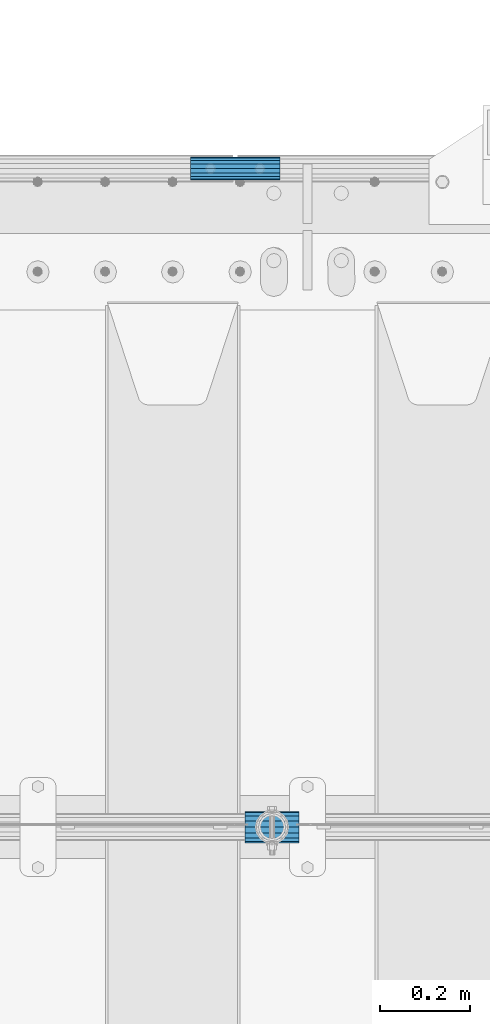
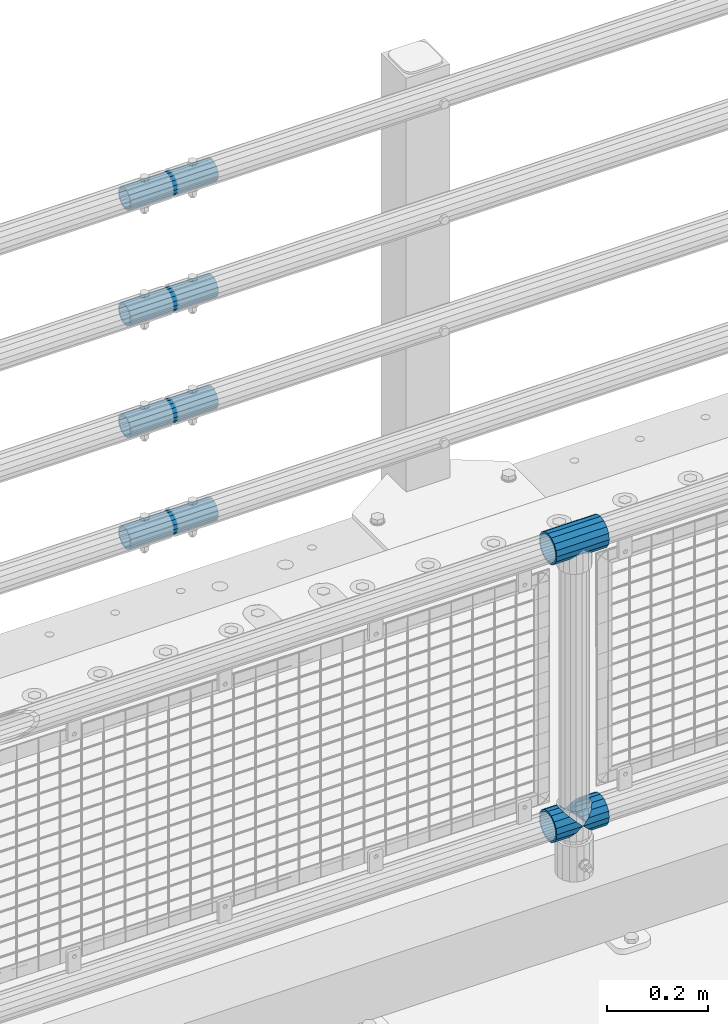
# One storey, part 123 of 208: 7 beams.
"""IFC2X3 building model written with IfcOpenShell, lengths in millimetres."""

from ifc_helpers import new_model, si_unit, frame, origin_with_axes, place, context, subcontext, project, spatial, faceted_brep, material, type_object, element, save


model = new_model("IFC2X3")

# Units and contexts
model_context = context("Model", 3, precision=1e-05, world=origin_with_axes())
body_context = subcontext(model_context, "Body", "Model", "MODEL_VIEW")
ifc_project = project(units=[si_unit("LENGTHUNIT", "METRE", prefix="MILLI"), si_unit("AREAUNIT", "SQUARE_METRE"), si_unit("VOLUMEUNIT", "CUBIC_METRE"), si_unit("MASSUNIT", "GRAM", prefix="KILO"), si_unit("TIMEUNIT", "SECOND"), si_unit("PLANEANGLEUNIT", "RADIAN"), si_unit("SOLIDANGLEUNIT", "STERADIAN"), si_unit("THERMODYNAMICTEMPERATUREUNIT", "DEGREE_CELSIUS"), si_unit("LUMINOUSINTENSITYUNIT", "LUMEN")], contexts=[model_context])

# Site, building, storey
site_placement = place(None, origin_with_axes())
site = spatial("IfcSite", under=ifc_project, at=site_placement, CompositionType="ELEMENT")
building_placement = place(site_placement, origin_with_axes())
building = spatial("IfcBuilding", under=site, at=building_placement, Name="Standard", CompositionType="ELEMENT")
storey_placement = place(building_placement, origin_with_axes())
storey = spatial("IfcBuildingStorey", under=building, at=storey_placement, Name="Undefined", CompositionType="ELEMENT", Elevation=0.0)

# Beams
ifc_material_1 = material(Name="Misc_Undefined")
beam_type_1 = type_object("IfcBeamType", PredefinedType="NOTDEFINED")
beam_1_placement = place(storey_placement, frame((-37089.15, 4664.5, 969.849999999999), z_axis=(0.0, 0.0, 1.0), x_axis=(1.0, 0.0, 0.0)))
element("IfcBeam", 1, at=beam_1_placement, inside=storey, type_object=beam_type_1, material=ifc_material_1, context=body_context, shape_type="Brep", body=[
    faceted_brep([(88.1897438117194, -11.6144421722802, -28.0397438117176), (88.1897438117194, -11.6144421722802, -32.8397438117178), (86.9623795176776, -13.4513226476329, -32.4743655677718), (81.6106908090114, -21.4606908090118, -27.1226768591068), (81.6106908090114, -21.4606908090118, -21.4606908090117), (76.531042407998, -24.8548033587067, -24.8548033587072), (71.7644421722835, -28.0397438117179, -20.0882031229861), (71.7644421722835, -28.0397438117179, -11.6144421722805), (60.1500000000015, -30.3500000000004, -16.6306603983687), (60.1500000000015, -30.35, 0.0), (48.5355578277195, -28.0397438117179, -20.0882031229861), (48.5355578277195, -28.0397438117179, -11.6144421722805), (43.7689575919976, -24.8548033587067, -24.8548033587072), (38.6893091909915, -21.4606908090118, -27.1226768591068), (38.6893091909915, -21.4606908090118, -21.4606908090117), (33.3376204823217, -13.4513226476329, -32.4743655677718), (32.1102561882835, -11.6144421722802, -32.8397438117178), (32.1102561882835, -11.6144421722802, -28.0397438117176), (29.8000000000029, 0.0, -35.15), (29.8000000000029, 0.0, -30.35), (32.1102561882835, 11.6144421722802, -32.8397438117175), (32.1102561882835, 11.6144421722802, -28.0397438117176), (33.3376204823217, 13.4513226476329, -32.4743655677718), (38.6893091909915, 21.4606908090118, -27.122676859108), (38.6893091909915, 21.4606908090118, -21.4606908090117), (43.7689575920012, 24.8548033587067, -24.8548033587072), (48.5355578277195, 28.0397438117179, -20.0882031229838), (48.5355578277195, 28.0397438117179, -11.6144421722805), (60.1500000000015, 30.3500000000004, -16.6306603983671), (60.1500000000015, 30.35, 0.0), (71.7644421722835, 28.0397438117179, -20.0882031229838), (71.7644421722835, 28.0397438117179, -11.6144421722805), (76.5310424080089, 24.8548033587067, -24.8548033587072), (81.6106908090114, 21.4606908090118, -27.122676859108), (81.6106908090114, 21.4606908090118, -21.4606908090117), (86.9623795176776, 13.4513226476329, -32.4743655677718), (88.1897438117194, 11.6144421722802, -32.8397438117175), (88.1897438117194, 11.6144421722802, -28.0397438117176), (90.5, 0.0, -35.15), (90.5, 0.0, -30.35), (0.0, -21.4606908090118, -21.4606908090136), (0.0, -28.0397438117179, -11.6144421722784), (0.0, -11.6144421722802, -28.0397438117143), (0.0, 0.0, -30.3499999999985), (0.0, 11.6144421722802, -28.0397438117143), (0.0, 21.4606908090118, -21.4606908090136), (0.0, 28.0397438117179, -11.6144421722784), (0.0, 30.3500000000004, 0.0), (0.0, 32.4743655677721, -13.4513226476338), (0.0, 35.1499999999996, 0.0), (120.299999999999, 35.1499999999996, 0.0), (120.299999999999, 32.4743655677721, -13.4513226476329), (0.0, 32.4743655677721, 13.4513226476338), (120.299999999999, 32.4743655677721, 13.4513226476329), (0.0, 24.8548033587067, 24.8548033587067), (120.299999999999, 24.8548033587067, 24.8548033587072), (0.0, 13.4513226476329, 32.4743655677739), (120.299999999999, 13.4513226476329, 32.4743655677718), (0.0, 0.0, 35.1499999999996), (120.299999999999, 0.0, 35.15), (0.0, -13.4513226476329, 32.4743655677739), (120.299999999999, -13.4513226476329, 32.4743655677718), (0.0, -24.8548033587067, 24.8548033587067), (120.299999999999, -24.8548033587067, 24.8548033587072), (0.0, -32.4743655677721, 13.4513226476338), (120.299999999999, -32.4743655677721, 13.4513226476329), (0.0, -35.1499999999996, 0.0), (120.299999999999, -35.1499999999996, 0.0), (0.0, -32.4743655677721, -13.4513226476338), (120.299999999999, -32.4743655677721, -13.4513226476329), (0.0, 24.8548033587067, -24.8548033587067), (0.0, 13.4513226476329, -32.4743655677739), (0.0, 0.0, -35.1499999999996), (0.0, -13.4513226476329, -32.4743655677739), (0.0, -24.8548033587067, -24.8548033587067), (0.0, 28.0397438117179, 11.6144421722784), (0.0, 21.4606908090118, 21.4606908090136), (0.0, 11.6144421722802, 28.0397438117143), (0.0, 0.0, 30.3499999999985), (0.0, -11.6144421722802, 28.0397438117143), (0.0, -21.4606908090118, 21.4606908090136), (0.0, -28.0397438117179, 11.6144421722784), (0.0, -30.3500000000004, 0.0), (120.299999999999, -30.3500000000004, 0.0), (120.299999999999, -28.0397438117179, -11.6144421722805), (120.299999999999, -21.4606908090118, -21.4606908090117), (120.299999999999, -11.6144421722802, -28.0397438117176), (120.299999999999, 0.0, -30.35), (120.299999999999, 21.4606908090118, -21.4606908090117), (120.299999999999, 28.0397438117179, -11.6144421722805), (120.299999999999, 11.6144421722802, -28.0397438117176), (120.299999999999, 30.3500000000004, 0.0), (120.299999999999, 28.0397438117179, 11.6144421722805), (120.299999999999, 21.4606908090118, 21.4606908090117), (120.299999999999, 11.6144421722802, 28.0397438117176), (120.299999999999, 0.0, 30.35), (120.299999999999, -11.6144421722802, 28.0397438117176), (120.299999999999, -21.4606908090118, 21.4606908090117), (120.299999999999, -28.0397438117179, 11.6144421722805), (120.299999999999, -24.8548033587067, -24.8548033587072), (120.299999999999, -13.4513226476329, -32.4743655677718), (120.299999999999, 0.0, -35.15), (120.299999999999, 13.4513226476329, -32.4743655677718), (120.299999999999, 24.8548033587067, -24.8548033587072)], [[[0, 1, 2, 3, 4]], [[4, 3, 5, 6, 7]], [[7, 6, 8, 9]], [[9, 8, 10, 11]], [[11, 10, 12, 13, 14]], [[14, 13, 15, 16, 17]], [[17, 16, 18, 19]], [[19, 18, 20, 21]], [[21, 20, 22, 23, 24]], [[24, 23, 25, 26, 27]], [[27, 26, 28, 29]], [[29, 28, 30, 31]], [[31, 30, 32, 33, 34]], [[34, 33, 35, 36, 37]], [[37, 36, 38, 39]], [[39, 38, 1, 0]], [[40, 41, 11, 14]], [[42, 40, 14, 17]], [[43, 42, 17, 19]], [[44, 43, 19, 21]], [[45, 44, 21, 24]], [[46, 45, 24, 27]], [[47, 46, 27, 29]], [[48, 49, 50, 51]], [[49, 52, 53, 50]], [[52, 54, 55, 53]], [[54, 56, 57, 55]], [[56, 58, 59, 57]], [[58, 60, 61, 59]], [[60, 62, 63, 61]], [[62, 64, 65, 63]], [[64, 66, 67, 65]], [[66, 68, 69, 67]], [[64, 62, 60, 58, 56, 54, 52, 49, 48, 70, 71, 72, 73, 74, 68, 66], [41, 40, 42, 43, 44, 45, 46, 47, 75, 76, 77, 78, 79, 80, 81, 82]], [[41, 82, 9, 11]], [[83, 84, 7, 9]], [[84, 85, 4, 7]], [[85, 86, 0, 4]], [[86, 87, 39, 0]], [[88, 89, 31, 34]], [[90, 88, 34, 37]], [[87, 90, 37, 39]], [[89, 91, 29, 31]], [[75, 47, 29, 91, 92]], [[76, 75, 92, 93]], [[77, 76, 93, 94]], [[78, 77, 94, 95]], [[79, 78, 95, 96]], [[80, 79, 96, 97]], [[81, 80, 97, 98]], [[9, 82, 81, 98, 83]], [[99, 100, 101, 102, 103, 51, 50, 53, 55, 57, 59, 61, 63, 65, 67, 69], [97, 96, 95, 94, 93, 92, 91, 89, 88, 90, 87, 86, 85, 84, 83, 98]], [[35, 102, 101, 38, 36]], [[32, 103, 102, 35, 33]], [[28, 26, 25, 70, 48, 51, 103, 32, 30]], [[22, 71, 70, 25, 23]], [[18, 72, 71, 22, 20]], [[73, 72, 18, 16, 15]], [[74, 73, 15, 13, 12]], [[99, 69, 68, 74, 12, 10, 8, 6, 5]], [[100, 99, 5, 3, 2]], [[101, 100, 2, 1, 38]]]),
])
beam_2_placement = place(storey_placement, frame((-37089.15, 4664.5, 298.17), z_axis=(0.0, 1.0, 0.0), x_axis=(1.0, 0.0, 0.0)))
element("IfcBeam", 2, at=beam_2_placement, inside=storey, type_object=beam_type_1, material=ifc_material_1, context=body_context, shape_type="Brep", body=[
    faceted_brep([(60.1500000000015, 0.0, -35.1499999999996), (46.6986773523677, 13.4513226476329, -32.4743655677721), (46.6986773523677, -13.4513226476329, -32.4743655677721), (33.0273231408937, 21.4606908090117, 21.4606908090118), (27.6756344322275, 26.812379517676, 13.4513226476329), (27.6756344322275, 32.4743655677717, 13.4513226476329), (35.2951966412948, 24.8548033587072, 24.8548033587067), (35.2951966412948, 16.3810424080032, 24.8548033587067), (27.3102561882915, 28.0397438117175, 11.6144421722802), (25.0, 30.35, 0.0), (25.0, 35.15, 0.0), (27.6756344322275, 26.8123795176755, -13.4513226476329), (27.6756344322275, 32.4743655677717, -13.4513226476329), (27.3102561882843, 28.0397438117175, -11.6144421722802), (35.2951966412948, 16.3810424080024, -24.8548033587067), (35.2951966412948, 24.8548033587072, -24.8548033587067), (33.0273231408864, 21.4606908090117, -21.4606908090118), (40.0617968770239, 11.6144421722805, -28.0397438117179), (43.5193396016402, 0.0, -30.3500000000004), (40.0617968770239, -11.6144421722805, -28.0397438117179), (35.2951966412948, -16.3810424080032, -24.8548033587067), (35.2951966412948, -24.8548033587072, -24.8548033587067), (33.0273231408864, -21.4606908090117, -21.4606908090118), (27.6756344322275, -26.812379517676, -13.4513226476329), (27.6756344322275, -32.4743655677717, -13.4513226476329), (27.3102561882843, -28.0397438117175, -11.6144421722802), (25.0, -30.35, 0.0), (25.0, -35.15, 0.0), (27.3102561882915, -28.0397438117175, 11.6144421722802), (27.6756344322275, -26.8123795176755, 13.4513226476329), (27.6756344322275, -32.4743655677717, 13.4513226476329), (33.0273231408937, -21.4606908090117, 21.4606908090118), (35.2951966412948, -16.3810424080032, 24.8548033587067), (35.2951966412948, -24.8548033587072, 24.8548033587067), (60.1500000000015, 0.0, 35.1499999999996), (46.6986773523677, -13.4513226476329, 32.4743655677721), (46.6986773523677, 13.4513226476329, 32.4743655677721), (40.0617968770093, -11.6144421722805, 28.0397438117179), (43.519339601633, 0.0, 30.3500000000004), (40.0617968770093, 11.6144421722805, 28.0397438117179), (0.0, -32.4743655677721, -13.4513226476338), (0.0, -24.8548033587067, -24.8548033587067), (0.0, -13.4513226476329, -32.4743655677739), (0.0, 0.0, -35.1499999999996), (0.0, 13.4513226476329, -32.4743655677739), (0.0, 24.8548033587067, -24.8548033587067), (0.0, 32.4743655677721, -13.4513226476338), (0.0, 35.1499999999996, 0.0), (0.0, 32.4743655677721, 13.4513226476338), (0.0, 24.8548033587067, 24.8548033587067), (0.0, 13.4513226476329, 32.4743655677739), (0.0, 0.0, 35.1499999999996), (0.0, -32.4743655677721, 13.4513226476338), (0.0, -35.1499999999996, 0.0), (0.0, -24.8548033587067, 24.8548033587067), (0.0, -13.4513226476329, 32.4743655677739), (0.0, -28.0397438117179, -11.6144421722784), (0.0, -21.4606908090118, -21.4606908090136), (0.0, -11.6144421722802, -28.0397438117143), (0.0, 0.0, -30.3499999999985), (0.0, 11.6144421722802, -28.0397438117143), (0.0, 21.4606908090118, -21.4606908090136), (0.0, 28.0397438117179, -11.6144421722784), (0.0, 30.3500000000004, 0.0), (0.0, 28.0397438117179, 11.6144421722784), (0.0, 21.4606908090118, 21.4606908090136), (0.0, 11.6144421722802, 28.0397438117143), (0.0, 0.0, 30.3499999999985), (0.0, -11.6144421722802, 28.0397438117143), (0.0, -21.4606908090118, 21.4606908090136), (0.0, -28.0397438117179, 11.6144421722784), (0.0, -30.3500000000004, 0.0)], [[[0, 1, 2]], [[3, 4, 5, 6, 7]], [[8, 9, 10, 5, 4]], [[11, 12, 10, 9, 13]], [[14, 15, 12, 11, 16]], [[2, 1, 15, 14, 17, 18, 19, 20, 21]], [[21, 20, 22, 23, 24]], [[24, 23, 25, 26, 27]], [[27, 26, 28, 29, 30]], [[30, 29, 31, 32, 33]], [[34, 35, 36]], [[33, 32, 37, 38, 39, 7, 6, 36, 35]], [[40, 41, 21, 24]], [[41, 42, 2, 21]], [[42, 43, 0, 2]], [[43, 44, 1, 0]], [[44, 45, 15, 1]], [[45, 46, 12, 15]], [[46, 47, 10, 12]], [[47, 48, 5, 10]], [[48, 49, 6, 5]], [[49, 50, 36, 6]], [[50, 51, 34, 36]], [[52, 53, 27, 30]], [[54, 52, 30, 33]], [[55, 54, 33, 35]], [[51, 55, 35, 34]], [[53, 40, 24, 27]], [[52, 54, 55, 51, 50, 49, 48, 47, 46, 45, 44, 43, 42, 41, 40, 53], [56, 57, 58, 59, 60, 61, 62, 63, 64, 65, 66, 67, 68, 69, 70, 71]], [[68, 67, 38, 37]], [[31, 69, 68, 37, 32]], [[28, 70, 69, 31, 29]], [[71, 70, 28, 26]], [[56, 71, 26, 25]], [[57, 56, 25, 23, 22]], [[58, 57, 22, 20, 19]], [[59, 58, 19, 18]], [[60, 59, 18, 17]], [[16, 61, 60, 17, 14]], [[13, 62, 61, 16, 11]], [[63, 62, 13, 9]], [[64, 63, 9, 8]], [[65, 64, 8, 4, 3]], [[66, 65, 3, 7, 39]], [[67, 66, 39, 38]]]),
])
beam_3_placement = place(storey_placement, frame((-37029.0, 4664.5, 298.17), z_axis=(0.0, 1.0, 0.0), x_axis=(1.0, 0.0, 0.0)))
element("IfcBeam", 3, at=beam_3_placement, inside=storey, type_object=beam_type_1, material=ifc_material_1, context=body_context, shape_type="Brep", body=[
    faceted_brep([(0.0, 0.0, 35.1499999999996), (13.4513226476338, 13.4513226476329, 32.4743655677721), (13.4513226476338, -13.4513226476329, 32.4743655677721), (32.4743655677739, -32.4743655677717, -13.4513226476329), (32.4743655677739, -26.8123795176766, -13.4513226476329), (27.1226768591077, -21.4606908090117, -21.4606908090118), (24.8548033587067, -16.3810424080039, -24.8548033587067), (24.8548033587067, -24.8548033587072, -24.8548033587067), (13.4513226476338, -13.4513226476329, -32.4743655677721), (13.4513226476338, 13.4513226476329, -32.4743655677721), (0.0, 0.0, -35.1499999999996), (20.0882031229849, -11.6144421722805, -28.0397438117179), (16.6306603983685, 0.0, -30.3500000000004), (20.0882031229849, 11.6144421722805, -28.0397438117179), (24.8548033587067, 16.3810424080023, -24.8548033587067), (24.8548033587067, 24.8548033587072, -24.8548033587067), (32.4743655677739, 26.8123795176755, -13.4513226476329), (32.4743655677739, 32.4743655677717, -13.4513226476329), (27.1226768591077, 21.4606908090117, -21.4606908090118), (35.1500000000015, 30.35, 0.0), (35.1500000000015, 35.15, 0.0), (32.8397438117172, 28.0397438117175, -11.6144421722802), (32.8397438117172, 28.0397438117175, 11.6144421722802), (32.4743655677739, 26.812379517676, 13.4513226476329), (32.4743655677739, 32.4743655677717, 13.4513226476329), (27.1226768591005, 21.4606908090117, 21.4606908090118), (24.8548033587067, 16.3810424080032, 24.8548033587067), (24.8548033587067, 24.8548033587072, 24.8548033587067), (20.0882031229921, 11.6144421722805, 28.0397438117179), (16.6306603983685, 0.0, 30.3500000000004), (20.0882031229921, -11.6144421722805, 28.0397438117179), (24.8548033587067, -16.3810424080039, 24.8548033587067), (24.8548033587067, -24.8548033587072, 24.8548033587067), (27.1226768591005, -21.4606908090117, 21.4606908090118), (32.4743655677739, -26.8123795176755, 13.4513226476329), (32.4743655677739, -32.4743655677717, 13.4513226476329), (32.8397438117172, -28.0397438117175, 11.6144421722802), (35.1500000000015, -30.35, 0.0), (35.1500000000015, -35.1499999999996, 0.0), (32.8397438117172, -28.0397438117175, -11.6144421722802), (60.1500000000015, -24.8548033587072, -24.8548033587067), (60.1500000000015, -32.4743655677717, -13.4513226476329), (60.1500000000015, -13.4513226476329, -32.4743655677721), (60.1500000000015, 0.0, -35.1499999999996), (60.1500000000015, 13.4513226476329, -32.4743655677721), (60.1500000000015, 24.8548033587072, -24.8548033587067), (60.1500000000015, 32.4743655677717, -13.4513226476329), (60.1500000000015, 35.15, 0.0), (60.1500000000015, 32.4743655677717, 13.4513226476329), (60.1500000000015, 24.8548033587072, 24.8548033587067), (60.1500000000015, 13.4513226476329, 32.4743655677721), (60.1500000000015, 0.0, 35.1499999999996), (60.1500000000015, -13.4513226476329, 32.4743655677721), (60.1500000000015, -24.8548033587072, 24.8548033587067), (60.1500000000015, -32.4743655677717, 13.4513226476329), (60.1500000000015, -35.15, 0.0), (60.1500000000015, -21.4606908090117, 21.4606908090118), (60.1500000000015, -11.6144421722805, 28.0397438117179), (60.1500000000015, 0.0, 30.3500000000004), (60.1500000000015, 11.6144421722805, 28.0397438117179), (60.1500000000015, 21.4606908090117, 21.4606908090118), (60.1500000000015, 28.0397438117175, 11.6144421722802), (60.1500000000015, 30.35, 0.0), (60.1500000000015, 28.0397438117175, -11.6144421722802), (60.1500000000015, 21.4606908090117, -21.4606908090118), (60.1500000000015, 11.6144421722805, -28.0397438117179), (60.1500000000015, 0.0, -30.3500000000004), (60.1500000000015, -11.6144421722805, -28.0397438117179), (60.1500000000015, -21.4606908090117, -21.4606908090118), (60.1500000000015, -28.0397438117175, -11.6144421722802), (60.1500000000015, -30.35, 0.0), (60.1500000000015, -28.0397438117175, 11.6144421722802)], [[[0, 1, 2]], [[3, 4, 5, 6, 7]], [[8, 9, 10]], [[7, 6, 11, 12, 13, 14, 15, 9, 8]], [[16, 17, 15, 14, 18]], [[19, 20, 17, 16, 21]], [[22, 23, 24, 20, 19]], [[25, 26, 27, 24, 23]], [[2, 1, 27, 26, 28, 29, 30, 31, 32]], [[32, 31, 33, 34, 35]], [[35, 34, 36, 37, 38]], [[38, 37, 39, 4, 3]], [[40, 41, 3, 7]], [[42, 40, 7, 8]], [[43, 42, 8, 10]], [[44, 43, 10, 9]], [[45, 44, 9, 15]], [[46, 45, 15, 17]], [[47, 46, 17, 20]], [[48, 47, 20, 24]], [[49, 48, 24, 27]], [[50, 49, 27, 1]], [[51, 50, 1, 0]], [[52, 51, 0, 2]], [[53, 52, 2, 32]], [[54, 53, 32, 35]], [[55, 54, 35, 38]], [[41, 55, 38, 3]], [[40, 42, 43, 44, 45, 46, 47, 48, 49, 50, 51, 52, 53, 54, 55, 41], [56, 57, 58, 59, 60, 61, 62, 63, 64, 65, 66, 67, 68, 69, 70, 71]], [[71, 70, 37, 36]], [[33, 56, 71, 36, 34]], [[30, 57, 56, 33, 31]], [[58, 57, 30, 29]], [[59, 58, 29, 28]], [[60, 59, 28, 26, 25]], [[61, 60, 25, 23, 22]], [[62, 61, 22, 19]], [[63, 62, 19, 21]], [[18, 64, 63, 21, 16]], [[13, 65, 64, 18, 14]], [[66, 65, 13, 12]], [[67, 66, 12, 11]], [[68, 67, 11, 6, 5]], [[69, 68, 5, 4, 39]], [[70, 69, 39, 37]]]),
])
ifc_material_2 = material()
beam_type_2 = type_object("IfcBeamType", PredefinedType="NOTDEFINED")
beam_4_placement = place(storey_placement, frame((-37211.0024970001, 6129.8500000004, 149.849999999725), z_axis=(0.0, 0.0, 1.0), x_axis=(1.0, 0.0, 0.0)))
element("IfcBeam", 4, at=beam_4_placement, inside=storey, type_object=beam_type_2, material=ifc_material_2, context=body_context, shape_type="Brep", body=[
    faceted_brep([(0.0, -21.8999999999996, 0.0), (0.0, -20.2329617619971, 8.38076716879547), (200.0, -20.2329617619971, 8.38076716879547), (200.0, -21.8999999999996, 0.0), (0.0, -15.4856385079856, 15.4856385079854), (200.0, -15.4856385079856, 15.4856385079854), (0.0, -8.3807671687955, 20.2329617619972), (200.0, -8.3807671687955, 20.2329617619972), (0.0, 0.0, 21.9), (200.0, 0.0, 21.9), (0.0, 8.3807671687955, 20.2329617619972), (200.0, 8.3807671687955, 20.2329617619972), (0.0, 15.4856385079856, 15.4856385079854), (200.0, 15.4856385079856, 15.4856385079854), (0.0, 20.2329617619971, 8.38076716879547), (200.0, 20.2329617619971, 8.38076716879547), (0.0, 21.8999999999996, 0.0), (200.0, 21.8999999999996, 0.0), (0.0, 20.2329617619971, -8.38076716879547), (200.0, 20.2329617619971, -8.38076716879547), (0.0, 15.4856385079856, -15.4856385079854), (200.0, 15.4856385079856, -15.4856385079854), (0.0, 8.3807671687955, -20.2329617619972), (200.0, 8.3807671687955, -20.2329617619972), (0.0, 0.0, -21.9), (200.0, 0.0, -21.9), (0.0, -8.3807671687955, -20.2329617619972), (200.0, -8.3807671687955, -20.2329617619972), (0.0, -15.4856385079856, -15.4856385079854), (200.0, -15.4856385079856, -15.4856385079854), (0.0, -20.2329617619971, -8.38076716879547), (200.0, -20.2329617619971, -8.38076716879547), (0.0, -25.5, 0.0), (0.0, -23.5589280790382, -9.7584275253098), (200.0, -23.5589280790382, -9.7584275253098), (200.0, -25.5, 0.0), (0.0, -18.0312229202573, -18.031222920257), (200.0, -18.0312229202573, -18.031222920257), (0.0, -9.75842752530934, -23.5589280790378), (200.0, -9.75842752530934, -23.5589280790378), (0.0, 0.0, -25.5), (200.0, 0.0, -25.5), (0.0, 9.75842752531025, -23.5589280790378), (200.0, 9.75842752531025, -23.5589280790378), (0.0, 18.0312229202573, -18.031222920257), (200.0, 18.0312229202573, -18.031222920257), (0.0, 23.5589280790382, -9.7584275253098), (200.0, 23.5589280790382, -9.7584275253098), (0.0, 25.5, 0.0), (200.0, 25.5, 0.0), (0.0, 23.5589280790382, 9.7584275253098), (200.0, 23.5589280790382, 9.7584275253098), (0.0, 18.0312229202573, 18.031222920257), (200.0, 18.0312229202573, 18.031222920257), (0.0, 9.75842752530934, 23.5589280790378), (200.0, 9.75842752530934, 23.5589280790378), (0.0, 0.0, 25.5), (200.0, 0.0, 25.5), (0.0, -9.75842752530934, 23.5589280790378), (200.0, -9.75842752530934, 23.5589280790378), (0.0, -18.0312229202573, 18.031222920257), (200.0, -18.0312229202573, 18.031222920257), (0.0, -23.5589280790382, 9.7584275253098), (200.0, -23.5589280790382, 9.7584275253098)], [[[0, 1, 2, 3]], [[1, 4, 5, 2]], [[4, 6, 7, 5]], [[6, 8, 9, 7]], [[8, 10, 11, 9]], [[10, 12, 13, 11]], [[12, 14, 15, 13]], [[14, 16, 17, 15]], [[16, 18, 19, 17]], [[18, 20, 21, 19]], [[20, 22, 23, 21]], [[22, 24, 25, 23]], [[24, 26, 27, 25]], [[26, 28, 29, 27]], [[28, 30, 31, 29]], [[30, 0, 3, 31]], [[32, 33, 34, 35]], [[33, 36, 37, 34]], [[36, 38, 39, 37]], [[38, 40, 41, 39]], [[40, 42, 43, 41]], [[42, 44, 45, 43]], [[44, 46, 47, 45]], [[46, 48, 49, 47]], [[48, 50, 51, 49]], [[50, 52, 53, 51]], [[52, 54, 55, 53]], [[54, 56, 57, 55]], [[56, 58, 59, 57]], [[58, 60, 61, 59]], [[60, 62, 63, 61]], [[62, 32, 35, 63]], [[37, 39, 41, 43, 45, 47, 49, 51, 53, 55, 57, 59, 61, 63, 35, 34], [5, 7, 9, 11, 13, 15, 17, 19, 21, 23, 25, 27, 29, 31, 3, 2]], [[62, 60, 58, 56, 54, 52, 50, 48, 46, 44, 42, 40, 38, 36, 33, 32], [30, 28, 26, 24, 22, 20, 18, 16, 14, 12, 10, 8, 6, 4, 1, 0]]]),
])
beam_5_placement = place(storey_placement, frame((-37211.0024970001, 6129.8500000004, 420.149999999724), z_axis=(0.0, 0.0, 1.0), x_axis=(1.0, 0.0, 0.0)))
element("IfcBeam", 5, at=beam_5_placement, inside=storey, type_object=beam_type_2, material=ifc_material_2, context=body_context, shape_type="Brep", body=[
    faceted_brep([(0.0, -21.8999999999996, 0.0), (0.0, -20.2329617619971, 8.38076716879547), (200.0, -20.2329617619971, 8.38076716879547), (200.0, -21.8999999999996, 0.0), (0.0, -15.4856385079856, 15.4856385079854), (200.0, -15.4856385079856, 15.4856385079854), (0.0, -8.3807671687955, 20.2329617619972), (200.0, -8.3807671687955, 20.2329617619972), (0.0, 0.0, 21.9), (200.0, 0.0, 21.9), (0.0, 8.3807671687955, 20.2329617619972), (200.0, 8.3807671687955, 20.2329617619972), (0.0, 15.4856385079856, 15.4856385079854), (200.0, 15.4856385079856, 15.4856385079854), (0.0, 20.2329617619971, 8.38076716879547), (200.0, 20.2329617619971, 8.38076716879547), (0.0, 21.8999999999996, 0.0), (200.0, 21.8999999999996, 0.0), (0.0, 20.2329617619971, -8.38076716879547), (200.0, 20.2329617619971, -8.38076716879547), (0.0, 15.4856385079856, -15.4856385079854), (200.0, 15.4856385079856, -15.4856385079854), (0.0, 8.3807671687955, -20.2329617619972), (200.0, 8.3807671687955, -20.2329617619972), (0.0, 0.0, -21.9), (200.0, 0.0, -21.9), (0.0, -8.3807671687955, -20.2329617619972), (200.0, -8.3807671687955, -20.2329617619972), (0.0, -15.4856385079856, -15.4856385079854), (200.0, -15.4856385079856, -15.4856385079854), (0.0, -20.2329617619971, -8.38076716879547), (200.0, -20.2329617619971, -8.38076716879547), (0.0, -25.5, 0.0), (0.0, -23.5589280790382, -9.7584275253098), (200.0, -23.5589280790382, -9.7584275253098), (200.0, -25.5, 0.0), (0.0, -18.0312229202573, -18.031222920257), (200.0, -18.0312229202573, -18.031222920257), (0.0, -9.75842752530934, -23.5589280790378), (200.0, -9.75842752530934, -23.5589280790378), (0.0, 0.0, -25.5), (200.0, 0.0, -25.5), (0.0, 9.75842752531025, -23.5589280790378), (200.0, 9.75842752531025, -23.5589280790378), (0.0, 18.0312229202573, -18.031222920257), (200.0, 18.0312229202573, -18.031222920257), (0.0, 23.5589280790382, -9.7584275253098), (200.0, 23.5589280790382, -9.7584275253098), (0.0, 25.5, 0.0), (200.0, 25.5, 0.0), (0.0, 23.5589280790382, 9.7584275253098), (200.0, 23.5589280790382, 9.7584275253098), (0.0, 18.0312229202573, 18.031222920257), (200.0, 18.0312229202573, 18.031222920257), (0.0, 9.75842752530934, 23.5589280790378), (200.0, 9.75842752530934, 23.5589280790378), (0.0, 0.0, 25.5), (200.0, 0.0, 25.5), (0.0, -9.75842752530934, 23.5589280790378), (200.0, -9.75842752530934, 23.5589280790378), (0.0, -18.0312229202573, 18.031222920257), (200.0, -18.0312229202573, 18.031222920257), (0.0, -23.5589280790382, 9.7584275253098), (200.0, -23.5589280790382, 9.7584275253098)], [[[0, 1, 2, 3]], [[1, 4, 5, 2]], [[4, 6, 7, 5]], [[6, 8, 9, 7]], [[8, 10, 11, 9]], [[10, 12, 13, 11]], [[12, 14, 15, 13]], [[14, 16, 17, 15]], [[16, 18, 19, 17]], [[18, 20, 21, 19]], [[20, 22, 23, 21]], [[22, 24, 25, 23]], [[24, 26, 27, 25]], [[26, 28, 29, 27]], [[28, 30, 31, 29]], [[30, 0, 3, 31]], [[32, 33, 34, 35]], [[33, 36, 37, 34]], [[36, 38, 39, 37]], [[38, 40, 41, 39]], [[40, 42, 43, 41]], [[42, 44, 45, 43]], [[44, 46, 47, 45]], [[46, 48, 49, 47]], [[48, 50, 51, 49]], [[50, 52, 53, 51]], [[52, 54, 55, 53]], [[54, 56, 57, 55]], [[56, 58, 59, 57]], [[58, 60, 61, 59]], [[60, 62, 63, 61]], [[62, 32, 35, 63]], [[37, 39, 41, 43, 45, 47, 49, 51, 53, 55, 57, 59, 61, 63, 35, 34], [5, 7, 9, 11, 13, 15, 17, 19, 21, 23, 25, 27, 29, 31, 3, 2]], [[62, 60, 58, 56, 54, 52, 50, 48, 46, 44, 42, 40, 38, 36, 33, 32], [30, 28, 26, 24, 22, 20, 18, 16, 14, 12, 10, 8, 6, 4, 1, 0]]]),
])
beam_6_placement = place(storey_placement, frame((-37211.0024970001, 6129.8500000004, 969.849999999725), z_axis=(0.0, 0.0, 1.0), x_axis=(1.0, 0.0, 0.0)))
element("IfcBeam", 6, at=beam_6_placement, inside=storey, type_object=beam_type_2, material=ifc_material_2, context=body_context, shape_type="Brep", body=[
    faceted_brep([(0.0, -21.8999999999996, 0.0), (0.0, -20.2329617619971, 8.38076716879547), (200.0, -20.2329617619971, 8.38076716879547), (200.0, -21.8999999999996, 0.0), (0.0, -15.4856385079856, 15.4856385079854), (200.0, -15.4856385079856, 15.4856385079854), (0.0, -8.3807671687955, 20.2329617619972), (200.0, -8.3807671687955, 20.2329617619972), (0.0, 0.0, 21.9), (200.0, 0.0, 21.9), (0.0, 8.3807671687955, 20.2329617619972), (200.0, 8.3807671687955, 20.2329617619972), (0.0, 15.4856385079856, 15.4856385079854), (200.0, 15.4856385079856, 15.4856385079854), (0.0, 20.2329617619971, 8.38076716879547), (200.0, 20.2329617619971, 8.38076716879547), (0.0, 21.8999999999996, 0.0), (200.0, 21.8999999999996, 0.0), (0.0, 20.2329617619971, -8.38076716879547), (200.0, 20.2329617619971, -8.38076716879547), (0.0, 15.4856385079856, -15.4856385079854), (200.0, 15.4856385079856, -15.4856385079854), (0.0, 8.3807671687955, -20.2329617619972), (200.0, 8.3807671687955, -20.2329617619972), (0.0, 0.0, -21.9), (200.0, 0.0, -21.9), (0.0, -8.3807671687955, -20.2329617619972), (200.0, -8.3807671687955, -20.2329617619972), (0.0, -15.4856385079856, -15.4856385079854), (200.0, -15.4856385079856, -15.4856385079854), (0.0, -20.2329617619971, -8.38076716879547), (200.0, -20.2329617619971, -8.38076716879547), (0.0, -25.5, 0.0), (0.0, -23.5589280790382, -9.7584275253098), (200.0, -23.5589280790382, -9.7584275253098), (200.0, -25.5, 0.0), (0.0, -18.0312229202573, -18.031222920257), (200.0, -18.0312229202573, -18.031222920257), (0.0, -9.75842752530934, -23.5589280790378), (200.0, -9.75842752530934, -23.5589280790378), (0.0, 0.0, -25.5), (200.0, 0.0, -25.5), (0.0, 9.75842752531025, -23.5589280790378), (200.0, 9.75842752531025, -23.5589280790378), (0.0, 18.0312229202573, -18.031222920257), (200.0, 18.0312229202573, -18.031222920257), (0.0, 23.5589280790382, -9.7584275253098), (200.0, 23.5589280790382, -9.7584275253098), (0.0, 25.5, 0.0), (200.0, 25.5, 0.0), (0.0, 23.5589280790382, 9.7584275253098), (200.0, 23.5589280790382, 9.7584275253098), (0.0, 18.0312229202573, 18.031222920257), (200.0, 18.0312229202573, 18.031222920257), (0.0, 9.75842752530934, 23.5589280790378), (200.0, 9.75842752530934, 23.5589280790378), (0.0, 0.0, 25.5), (200.0, 0.0, 25.5), (0.0, -9.75842752530934, 23.5589280790378), (200.0, -9.75842752530934, 23.5589280790378), (0.0, -18.0312229202573, 18.031222920257), (200.0, -18.0312229202573, 18.031222920257), (0.0, -23.5589280790382, 9.7584275253098), (200.0, -23.5589280790382, 9.7584275253098)], [[[0, 1, 2, 3]], [[1, 4, 5, 2]], [[4, 6, 7, 5]], [[6, 8, 9, 7]], [[8, 10, 11, 9]], [[10, 12, 13, 11]], [[12, 14, 15, 13]], [[14, 16, 17, 15]], [[16, 18, 19, 17]], [[18, 20, 21, 19]], [[20, 22, 23, 21]], [[22, 24, 25, 23]], [[24, 26, 27, 25]], [[26, 28, 29, 27]], [[28, 30, 31, 29]], [[30, 0, 3, 31]], [[32, 33, 34, 35]], [[33, 36, 37, 34]], [[36, 38, 39, 37]], [[38, 40, 41, 39]], [[40, 42, 43, 41]], [[42, 44, 45, 43]], [[44, 46, 47, 45]], [[46, 48, 49, 47]], [[48, 50, 51, 49]], [[50, 52, 53, 51]], [[52, 54, 55, 53]], [[54, 56, 57, 55]], [[56, 58, 59, 57]], [[58, 60, 61, 59]], [[60, 62, 63, 61]], [[62, 32, 35, 63]], [[37, 39, 41, 43, 45, 47, 49, 51, 53, 55, 57, 59, 61, 63, 35, 34], [5, 7, 9, 11, 13, 15, 17, 19, 21, 23, 25, 27, 29, 31, 3, 2]], [[62, 60, 58, 56, 54, 52, 50, 48, 46, 44, 42, 40, 38, 36, 33, 32], [30, 28, 26, 24, 22, 20, 18, 16, 14, 12, 10, 8, 6, 4, 1, 0]]]),
])
beam_7_placement = place(storey_placement, frame((-37211.0024970001, 6129.8500000004, 689.849999999725), z_axis=(0.0, 0.0, 1.0), x_axis=(1.0, 0.0, 0.0)))
element("IfcBeam", 7, at=beam_7_placement, inside=storey, type_object=beam_type_2, material=ifc_material_2, context=body_context, shape_type="Brep", body=[
    faceted_brep([(0.0, -21.8999999999996, 0.0), (0.0, -20.2329617619971, 8.38076716879547), (200.0, -20.2329617619971, 8.38076716879547), (200.0, -21.8999999999996, 0.0), (0.0, -15.4856385079856, 15.4856385079854), (200.0, -15.4856385079856, 15.4856385079854), (0.0, -8.3807671687955, 20.2329617619972), (200.0, -8.3807671687955, 20.2329617619972), (0.0, 0.0, 21.9), (200.0, 0.0, 21.9), (0.0, 8.3807671687955, 20.2329617619972), (200.0, 8.3807671687955, 20.2329617619972), (0.0, 15.4856385079856, 15.4856385079854), (200.0, 15.4856385079856, 15.4856385079854), (0.0, 20.2329617619971, 8.38076716879547), (200.0, 20.2329617619971, 8.38076716879547), (0.0, 21.8999999999996, 0.0), (200.0, 21.8999999999996, 0.0), (0.0, 20.2329617619971, -8.38076716879547), (200.0, 20.2329617619971, -8.38076716879547), (0.0, 15.4856385079856, -15.4856385079854), (200.0, 15.4856385079856, -15.4856385079854), (0.0, 8.3807671687955, -20.2329617619972), (200.0, 8.3807671687955, -20.2329617619972), (0.0, 0.0, -21.9), (200.0, 0.0, -21.9), (0.0, -8.3807671687955, -20.2329617619972), (200.0, -8.3807671687955, -20.2329617619972), (0.0, -15.4856385079856, -15.4856385079854), (200.0, -15.4856385079856, -15.4856385079854), (0.0, -20.2329617619971, -8.38076716879547), (200.0, -20.2329617619971, -8.38076716879547), (0.0, -25.5, 0.0), (0.0, -23.5589280790382, -9.7584275253098), (200.0, -23.5589280790382, -9.7584275253098), (200.0, -25.5, 0.0), (0.0, -18.0312229202573, -18.031222920257), (200.0, -18.0312229202573, -18.031222920257), (0.0, -9.75842752530934, -23.5589280790378), (200.0, -9.75842752530934, -23.5589280790378), (0.0, 0.0, -25.5), (200.0, 0.0, -25.5), (0.0, 9.75842752531025, -23.5589280790378), (200.0, 9.75842752531025, -23.5589280790378), (0.0, 18.0312229202573, -18.031222920257), (200.0, 18.0312229202573, -18.031222920257), (0.0, 23.5589280790382, -9.7584275253098), (200.0, 23.5589280790382, -9.7584275253098), (0.0, 25.5, 0.0), (200.0, 25.5, 0.0), (0.0, 23.5589280790382, 9.7584275253098), (200.0, 23.5589280790382, 9.7584275253098), (0.0, 18.0312229202573, 18.031222920257), (200.0, 18.0312229202573, 18.031222920257), (0.0, 9.75842752530934, 23.5589280790378), (200.0, 9.75842752530934, 23.5589280790378), (0.0, 0.0, 25.5), (200.0, 0.0, 25.5), (0.0, -9.75842752530934, 23.5589280790378), (200.0, -9.75842752530934, 23.5589280790378), (0.0, -18.0312229202573, 18.031222920257), (200.0, -18.0312229202573, 18.031222920257), (0.0, -23.5589280790382, 9.7584275253098), (200.0, -23.5589280790382, 9.7584275253098)], [[[0, 1, 2, 3]], [[1, 4, 5, 2]], [[4, 6, 7, 5]], [[6, 8, 9, 7]], [[8, 10, 11, 9]], [[10, 12, 13, 11]], [[12, 14, 15, 13]], [[14, 16, 17, 15]], [[16, 18, 19, 17]], [[18, 20, 21, 19]], [[20, 22, 23, 21]], [[22, 24, 25, 23]], [[24, 26, 27, 25]], [[26, 28, 29, 27]], [[28, 30, 31, 29]], [[30, 0, 3, 31]], [[32, 33, 34, 35]], [[33, 36, 37, 34]], [[36, 38, 39, 37]], [[38, 40, 41, 39]], [[40, 42, 43, 41]], [[42, 44, 45, 43]], [[44, 46, 47, 45]], [[46, 48, 49, 47]], [[48, 50, 51, 49]], [[50, 52, 53, 51]], [[52, 54, 55, 53]], [[54, 56, 57, 55]], [[56, 58, 59, 57]], [[58, 60, 61, 59]], [[60, 62, 63, 61]], [[62, 32, 35, 63]], [[37, 39, 41, 43, 45, 47, 49, 51, 53, 55, 57, 59, 61, 63, 35, 34], [5, 7, 9, 11, 13, 15, 17, 19, 21, 23, 25, 27, 29, 31, 3, 2]], [[62, 60, 58, 56, 54, 52, 50, 48, 46, 44, 42, 40, 38, 36, 33, 32], [30, 28, 26, 24, 22, 20, 18, 16, 14, 12, 10, 8, 6, 4, 1, 0]]]),
])

save(model, "model.ifc")
